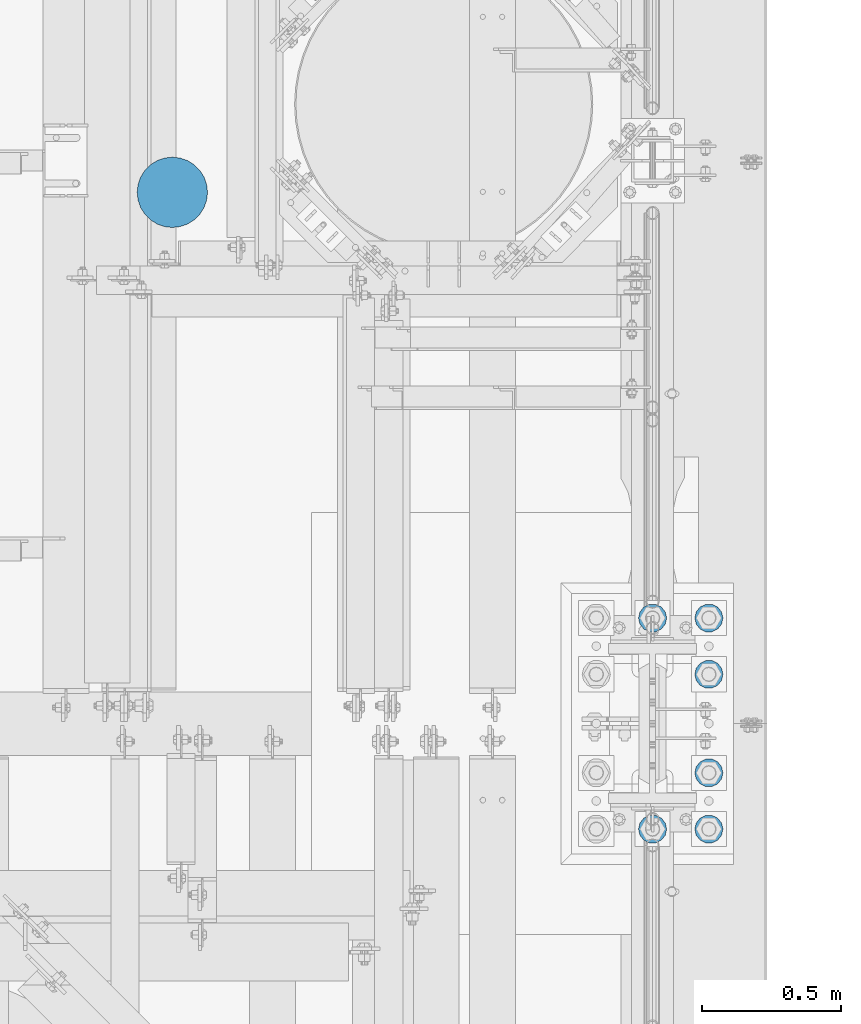
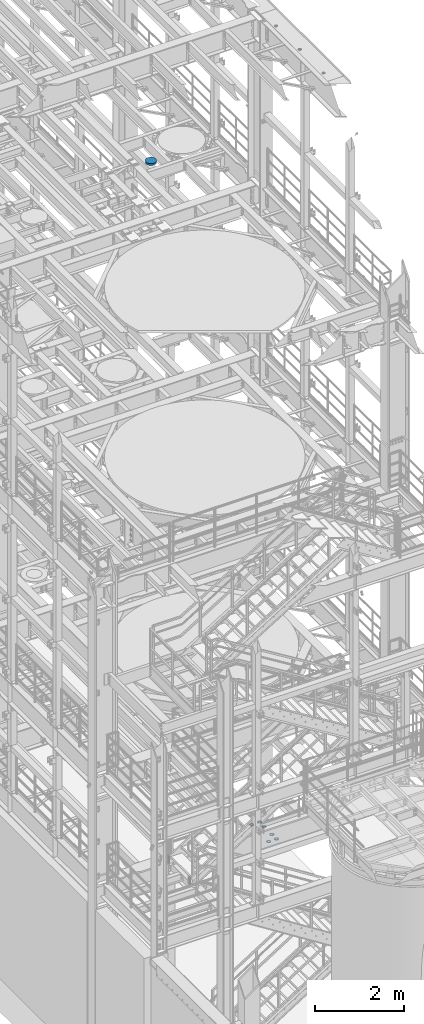
# One storey, part 841 of 1876: 7 columns, 2 elements without a shape of their own.
"""IFC2X3 building model written with IfcOpenShell, lengths in millimetres."""

from ifc_helpers import new_model, si_unit, frame, origin_with_axes, place, context, subcontext, project, spatial, faceted_brep, material, type_object, element, aggregate, save


model = new_model("IFC2X3")

# Units and contexts
model_context = context("Model", 3, precision=1e-05, world=origin_with_axes())
body_context = subcontext(model_context, "Body", "Model", "MODEL_VIEW")
ifc_project = project(units=[si_unit("LENGTHUNIT", "METRE", prefix="MILLI"), si_unit("AREAUNIT", "SQUARE_METRE"), si_unit("VOLUMEUNIT", "CUBIC_METRE"), si_unit("MASSUNIT", "GRAM", prefix="KILO"), si_unit("TIMEUNIT", "SECOND"), si_unit("PLANEANGLEUNIT", "RADIAN"), si_unit("SOLIDANGLEUNIT", "STERADIAN"), si_unit("THERMODYNAMICTEMPERATUREUNIT", "DEGREE_CELSIUS"), si_unit("LUMINOUSINTENSITYUNIT", "LUMEN")], contexts=[model_context])

# Site, building, storey
site_placement = place(None, origin_with_axes())
site = spatial("IfcSite", under=ifc_project, at=site_placement, CompositionType="ELEMENT")
building_placement = place(site_placement, origin_with_axes())
building = spatial("IfcBuilding", under=site, at=building_placement, Name="Undefined", CompositionType="ELEMENT")
storey_placement = place(building_placement, origin_with_axes())
storey = spatial("IfcBuildingStorey", under=building, at=storey_placement, Name="Undefined", CompositionType="ELEMENT", Elevation=0.0)

# Assembly, columns
assembly_1_placement = place(storey_placement, origin_with_axes())
assembly_1 = element("IfcElementAssembly", 1, at=assembly_1_placement, inside=storey, Name="TEMPLATE", AssemblyPlace="NOTDEFINED", PredefinedType="RIGID_FRAME")
ifc_material_1 = material(Name="STEEL/F436")
column_type_1 = type_object("IfcColumnType", Name="2_WASHER", PredefinedType="NOTDEFINED")
column_1_placement = place(assembly_1_placement, frame((7620.0, 1143.0, 38.1), z_axis=(0.0, -1.0, 0.0), x_axis=(0.0, 0.0, -1.0)))
column_1 = element("IfcColumn", 2, at=column_1_placement, type_object=column_type_1, material=ifc_material_1, Name="WASHER", ObjectType="2_WASHER", context=body_context, shape_type="Brep", body=[
    faceted_brep([(0.0, -50.7999992370605, 9.09494701772928e-13), (0.0, -45.7692178020588, -22.0412936161442), (4.7625, -45.7692178020588, -22.0412936161442), (4.7625, -50.7999992370605, 9.09494701772928e-13), (0.0, -31.6732814587394, -39.7170387128856), (4.7625, -31.6732814587394, -39.7170387128856), (0.0, -11.3040632752118, -49.5263371950259), (4.7625, -11.3040632752118, -49.5263371950259), (0.0, 11.30406327521, -49.5263371950264), (4.7625, 11.30406327521, -49.5263371950264), (0.0, 31.6732814587385, -39.7170387128867), (4.7625, 31.6732814587385, -39.7170387128867), (0.0, 45.7692178020579, -22.041293616146), (4.7625, 45.7692178020579, -22.041293616146), (0.0, 50.7999992370605, -9.09494701772928e-13), (4.7625, 50.7999992370605, -9.09494701772928e-13), (0.0, 45.7692178020588, 22.0412936161442), (4.7625, 45.7692178020588, 22.0412936161442), (0.0, 31.6732814587394, 39.7170387128856), (4.7625, 31.6732814587394, 39.7170387128856), (0.0, 11.3040632752118, 49.5263371950259), (4.7625, 11.3040632752118, 49.5263371950259), (0.0, -11.30406327521, 49.5263371950264), (4.7625, -11.30406327521, 49.5263371950264), (0.0, -31.6732814587385, 39.7170387128867), (4.7625, -31.6732814587385, 39.7170387128867), (0.0, -45.7692178020579, 22.041293616146), (4.7625, -45.7692178020579, 22.041293616146), (0.0, 0.0, 26.9869995117188), (0.0, 11.7093983825444, 24.3146012721213), (4.7625, 11.7093983825444, 24.3146012721213), (4.7625, 0.0, 26.9869995117188), (0.0, 21.0996520289491, 16.8262864224157), (4.7625, 21.0996520289491, 16.8262864224157), (0.0, 26.3108629296712, 6.00524193584533), (4.7625, 26.3108629296712, 6.00524193584533), (0.0, 26.3108629296712, -6.00524193584533), (4.7625, 26.3108629296712, -6.00524193584533), (0.0, 21.0996520289491, -16.8262864224157), (4.7625, 21.0996520289491, -16.8262864224157), (0.0, 11.7093983825444, -24.3146012721213), (4.7625, 11.7093983825444, -24.3146012721213), (0.0, 0.0, -26.9869995117188), (4.7625, 0.0, -26.9869995117188), (0.0, -11.7093983825444, -24.3146012721213), (4.7625, -11.7093983825444, -24.3146012721213), (0.0, -21.0996520289491, -16.8262864224157), (4.7625, -21.0996520289491, -16.8262864224157), (0.0, -26.3108629296712, -6.00524193584533), (4.7625, -26.3108629296712, -6.00524193584533), (0.0, -26.3108629296712, 6.00524193584533), (4.7625, -26.3108629296712, 6.00524193584533), (0.0, -21.0996520289491, 16.8262864224157), (4.7625, -21.0996520289491, 16.8262864224157), (0.0, -11.7093983825444, 24.3146012721213), (4.7625, -11.7093983825444, 24.3146012721213)], [[[0, 1, 2, 3]], [[1, 4, 5, 2]], [[4, 6, 7, 5]], [[6, 8, 9, 7]], [[8, 10, 11, 9]], [[10, 12, 13, 11]], [[12, 14, 15, 13]], [[14, 16, 17, 15]], [[16, 18, 19, 17]], [[18, 20, 21, 19]], [[20, 22, 23, 21]], [[22, 24, 25, 23]], [[24, 26, 27, 25]], [[26, 0, 3, 27]], [[28, 29, 30, 31]], [[29, 32, 33, 30]], [[32, 34, 35, 33]], [[34, 36, 37, 35]], [[36, 38, 39, 37]], [[38, 40, 41, 39]], [[40, 42, 43, 41]], [[42, 44, 45, 43]], [[44, 46, 47, 45]], [[46, 48, 49, 47]], [[48, 50, 51, 49]], [[50, 52, 53, 51]], [[52, 54, 55, 53]], [[54, 28, 31, 55]], [[5, 7, 9, 11, 13, 15, 17, 19, 21, 23, 25, 27, 3, 2], [33, 35, 37, 39, 41, 43, 45, 47, 49, 51, 53, 55, 31, 30]], [[26, 24, 22, 20, 18, 16, 14, 12, 10, 8, 6, 4, 1, 0], [54, 52, 50, 48, 46, 44, 42, 40, 38, 36, 34, 32, 29, 28]]]),
])
column_2_placement = place(assembly_1_placement, frame((7823.2, 1143.0, 38.1), z_axis=(0.0, 1.0, 0.0), x_axis=(0.0, 0.0, -1.0)))
column_2 = element("IfcColumn", 3, at=column_2_placement, type_object=column_type_1, material=ifc_material_1, Name="WASHER", ObjectType="2_WASHER", context=body_context, shape_type="Brep", body=[
    faceted_brep([(0.0, -50.7999992370605, 9.09494701772928e-13), (0.0, -45.7692178020588, -22.0412936161442), (4.7625, -45.7692178020588, -22.0412936161442), (4.7625, -50.7999992370605, 9.09494701772928e-13), (0.0, -31.6732814587394, -39.7170387128856), (4.7625, -31.6732814587394, -39.7170387128856), (0.0, -11.3040632752118, -49.5263371950259), (4.7625, -11.3040632752118, -49.5263371950259), (0.0, 11.30406327521, -49.5263371950264), (4.7625, 11.30406327521, -49.5263371950264), (0.0, 31.6732814587385, -39.7170387128867), (4.7625, 31.6732814587385, -39.7170387128867), (0.0, 45.7692178020579, -22.041293616146), (4.7625, 45.7692178020579, -22.041293616146), (0.0, 50.7999992370605, -9.09494701772928e-13), (4.7625, 50.7999992370605, -9.09494701772928e-13), (0.0, 45.7692178020588, 22.0412936161442), (4.7625, 45.7692178020588, 22.0412936161442), (0.0, 31.6732814587394, 39.7170387128856), (4.7625, 31.6732814587394, 39.7170387128856), (0.0, 11.3040632752118, 49.5263371950259), (4.7625, 11.3040632752118, 49.5263371950259), (0.0, -11.30406327521, 49.5263371950264), (4.7625, -11.30406327521, 49.5263371950264), (0.0, -31.6732814587385, 39.7170387128867), (4.7625, -31.6732814587385, 39.7170387128867), (0.0, -45.7692178020579, 22.041293616146), (4.7625, -45.7692178020579, 22.041293616146), (0.0, 0.0, 26.9869995117188), (0.0, 11.7093983825444, 24.3146012721213), (4.7625, 11.7093983825444, 24.3146012721213), (4.7625, 0.0, 26.9869995117188), (0.0, 21.0996520289491, 16.8262864224157), (4.7625, 21.0996520289491, 16.8262864224157), (0.0, 26.3108629296712, 6.00524193584533), (4.7625, 26.3108629296712, 6.00524193584533), (0.0, 26.3108629296712, -6.00524193584533), (4.7625, 26.3108629296712, -6.00524193584533), (0.0, 21.0996520289491, -16.8262864224157), (4.7625, 21.0996520289491, -16.8262864224157), (0.0, 11.7093983825444, -24.3146012721213), (4.7625, 11.7093983825444, -24.3146012721213), (0.0, 0.0, -26.9869995117188), (4.7625, 0.0, -26.9869995117188), (0.0, -11.7093983825444, -24.3146012721213), (4.7625, -11.7093983825444, -24.3146012721213), (0.0, -21.0996520289491, -16.8262864224157), (4.7625, -21.0996520289491, -16.8262864224157), (0.0, -26.3108629296712, -6.00524193584533), (4.7625, -26.3108629296712, -6.00524193584533), (0.0, -26.3108629296712, 6.00524193584533), (4.7625, -26.3108629296712, 6.00524193584533), (0.0, -21.0996520289491, 16.8262864224157), (4.7625, -21.0996520289491, 16.8262864224157), (0.0, -11.7093983825444, 24.3146012721213), (4.7625, -11.7093983825444, 24.3146012721213)], [[[0, 1, 2, 3]], [[1, 4, 5, 2]], [[4, 6, 7, 5]], [[6, 8, 9, 7]], [[8, 10, 11, 9]], [[10, 12, 13, 11]], [[12, 14, 15, 13]], [[14, 16, 17, 15]], [[16, 18, 19, 17]], [[18, 20, 21, 19]], [[20, 22, 23, 21]], [[22, 24, 25, 23]], [[24, 26, 27, 25]], [[26, 0, 3, 27]], [[28, 29, 30, 31]], [[29, 32, 33, 30]], [[32, 34, 35, 33]], [[34, 36, 37, 35]], [[36, 38, 39, 37]], [[38, 40, 41, 39]], [[40, 42, 43, 41]], [[42, 44, 45, 43]], [[44, 46, 47, 45]], [[46, 48, 49, 47]], [[48, 50, 51, 49]], [[50, 52, 53, 51]], [[52, 54, 55, 53]], [[54, 28, 31, 55]], [[5, 7, 9, 11, 13, 15, 17, 19, 21, 23, 25, 27, 3, 2], [33, 35, 37, 39, 41, 43, 45, 47, 49, 51, 53, 55, 31, 30]], [[26, 24, 22, 20, 18, 16, 14, 12, 10, 8, 6, 4, 1, 0], [54, 52, 50, 48, 46, 44, 42, 40, 38, 36, 34, 32, 29, 28]]]),
])
column_3_placement = place(assembly_1_placement, frame((7823.2, 1346.2, 38.1), z_axis=(0.0, 1.0, 0.0), x_axis=(0.0, 0.0, -1.0)))
column_3 = element("IfcColumn", 4, at=column_3_placement, type_object=column_type_1, material=ifc_material_1, Name="WASHER", ObjectType="2_WASHER", context=body_context, shape_type="Brep", body=[
    faceted_brep([(0.0, -50.7999992370605, 9.09494701772928e-13), (0.0, -45.7692178020588, -22.0412936161442), (4.7625, -45.7692178020588, -22.0412936161442), (4.7625, -50.7999992370605, 9.09494701772928e-13), (0.0, -31.6732814587394, -39.7170387128856), (4.7625, -31.6732814587394, -39.7170387128856), (0.0, -11.3040632752118, -49.5263371950259), (4.7625, -11.3040632752118, -49.5263371950259), (0.0, 11.30406327521, -49.5263371950264), (4.7625, 11.30406327521, -49.5263371950264), (0.0, 31.6732814587385, -39.7170387128867), (4.7625, 31.6732814587385, -39.7170387128867), (0.0, 45.7692178020579, -22.041293616146), (4.7625, 45.7692178020579, -22.041293616146), (0.0, 50.7999992370605, -9.09494701772928e-13), (4.7625, 50.7999992370605, -9.09494701772928e-13), (0.0, 45.7692178020588, 22.0412936161442), (4.7625, 45.7692178020588, 22.0412936161442), (0.0, 31.6732814587394, 39.7170387128856), (4.7625, 31.6732814587394, 39.7170387128856), (0.0, 11.3040632752118, 49.5263371950259), (4.7625, 11.3040632752118, 49.5263371950259), (0.0, -11.30406327521, 49.5263371950264), (4.7625, -11.30406327521, 49.5263371950264), (0.0, -31.6732814587385, 39.7170387128867), (4.7625, -31.6732814587385, 39.7170387128867), (0.0, -45.7692178020579, 22.041293616146), (4.7625, -45.7692178020579, 22.041293616146), (0.0, 0.0, 26.9869995117188), (0.0, 11.7093983825444, 24.3146012721213), (4.7625, 11.7093983825444, 24.3146012721213), (4.7625, 0.0, 26.9869995117188), (0.0, 21.0996520289491, 16.8262864224157), (4.7625, 21.0996520289491, 16.8262864224157), (0.0, 26.3108629296712, 6.00524193584533), (4.7625, 26.3108629296712, 6.00524193584533), (0.0, 26.3108629296712, -6.00524193584533), (4.7625, 26.3108629296712, -6.00524193584533), (0.0, 21.0996520289491, -16.8262864224157), (4.7625, 21.0996520289491, -16.8262864224157), (0.0, 11.7093983825444, -24.3146012721213), (4.7625, 11.7093983825444, -24.3146012721213), (0.0, 0.0, -26.9869995117188), (4.7625, 0.0, -26.9869995117188), (0.0, -11.7093983825444, -24.3146012721213), (4.7625, -11.7093983825444, -24.3146012721213), (0.0, -21.0996520289491, -16.8262864224157), (4.7625, -21.0996520289491, -16.8262864224157), (0.0, -26.3108629296712, -6.00524193584533), (4.7625, -26.3108629296712, -6.00524193584533), (0.0, -26.3108629296712, 6.00524193584533), (4.7625, -26.3108629296712, 6.00524193584533), (0.0, -21.0996520289491, 16.8262864224157), (4.7625, -21.0996520289491, 16.8262864224157), (0.0, -11.7093983825444, 24.3146012721213), (4.7625, -11.7093983825444, 24.3146012721213)], [[[0, 1, 2, 3]], [[1, 4, 5, 2]], [[4, 6, 7, 5]], [[6, 8, 9, 7]], [[8, 10, 11, 9]], [[10, 12, 13, 11]], [[12, 14, 15, 13]], [[14, 16, 17, 15]], [[16, 18, 19, 17]], [[18, 20, 21, 19]], [[20, 22, 23, 21]], [[22, 24, 25, 23]], [[24, 26, 27, 25]], [[26, 0, 3, 27]], [[28, 29, 30, 31]], [[29, 32, 33, 30]], [[32, 34, 35, 33]], [[34, 36, 37, 35]], [[36, 38, 39, 37]], [[38, 40, 41, 39]], [[40, 42, 43, 41]], [[42, 44, 45, 43]], [[44, 46, 47, 45]], [[46, 48, 49, 47]], [[48, 50, 51, 49]], [[50, 52, 53, 51]], [[52, 54, 55, 53]], [[54, 28, 31, 55]], [[5, 7, 9, 11, 13, 15, 17, 19, 21, 23, 25, 27, 3, 2], [33, 35, 37, 39, 41, 43, 45, 47, 49, 51, 53, 55, 31, 30]], [[26, 24, 22, 20, 18, 16, 14, 12, 10, 8, 6, 4, 1, 0], [54, 52, 50, 48, 46, 44, 42, 40, 38, 36, 34, 32, 29, 28]]]),
])
column_4_placement = place(assembly_1_placement, frame((7823.2, 1701.8, 38.1), z_axis=(0.0, 1.0, 0.0), x_axis=(0.0, 0.0, -1.0)))
column_4 = element("IfcColumn", 5, at=column_4_placement, type_object=column_type_1, material=ifc_material_1, Name="WASHER", ObjectType="2_WASHER", context=body_context, shape_type="Brep", body=[
    faceted_brep([(0.0, -50.7999992370605, 9.09494701772928e-13), (0.0, -45.7692178020588, -22.0412936161442), (4.7625, -45.7692178020588, -22.0412936161442), (4.7625, -50.7999992370605, 9.09494701772928e-13), (0.0, -31.6732814587394, -39.7170387128856), (4.7625, -31.6732814587394, -39.7170387128856), (0.0, -11.3040632752118, -49.5263371950259), (4.7625, -11.3040632752118, -49.5263371950259), (0.0, 11.30406327521, -49.5263371950264), (4.7625, 11.30406327521, -49.5263371950264), (0.0, 31.6732814587385, -39.7170387128867), (4.7625, 31.6732814587385, -39.7170387128867), (0.0, 45.7692178020579, -22.041293616146), (4.7625, 45.7692178020579, -22.041293616146), (0.0, 50.7999992370605, -9.09494701772928e-13), (4.7625, 50.7999992370605, -9.09494701772928e-13), (0.0, 45.7692178020588, 22.0412936161442), (4.7625, 45.7692178020588, 22.0412936161442), (0.0, 31.6732814587394, 39.7170387128856), (4.7625, 31.6732814587394, 39.7170387128856), (0.0, 11.3040632752118, 49.5263371950259), (4.7625, 11.3040632752118, 49.5263371950259), (0.0, -11.30406327521, 49.5263371950264), (4.7625, -11.30406327521, 49.5263371950264), (0.0, -31.6732814587385, 39.7170387128867), (4.7625, -31.6732814587385, 39.7170387128867), (0.0, -45.7692178020579, 22.041293616146), (4.7625, -45.7692178020579, 22.041293616146), (0.0, 0.0, 26.9869995117188), (0.0, 11.7093983825444, 24.3146012721213), (4.7625, 11.7093983825444, 24.3146012721213), (4.7625, 0.0, 26.9869995117188), (0.0, 21.0996520289491, 16.8262864224157), (4.7625, 21.0996520289491, 16.8262864224157), (0.0, 26.3108629296712, 6.00524193584533), (4.7625, 26.3108629296712, 6.00524193584533), (0.0, 26.3108629296712, -6.00524193584533), (4.7625, 26.3108629296712, -6.00524193584533), (0.0, 21.0996520289491, -16.8262864224157), (4.7625, 21.0996520289491, -16.8262864224157), (0.0, 11.7093983825444, -24.3146012721213), (4.7625, 11.7093983825444, -24.3146012721213), (0.0, 0.0, -26.9869995117188), (4.7625, 0.0, -26.9869995117188), (0.0, -11.7093983825444, -24.3146012721213), (4.7625, -11.7093983825444, -24.3146012721213), (0.0, -21.0996520289491, -16.8262864224157), (4.7625, -21.0996520289491, -16.8262864224157), (0.0, -26.3108629296712, -6.00524193584533), (4.7625, -26.3108629296712, -6.00524193584533), (0.0, -26.3108629296712, 6.00524193584533), (4.7625, -26.3108629296712, 6.00524193584533), (0.0, -21.0996520289491, 16.8262864224157), (4.7625, -21.0996520289491, 16.8262864224157), (0.0, -11.7093983825444, 24.3146012721213), (4.7625, -11.7093983825444, 24.3146012721213)], [[[0, 1, 2, 3]], [[1, 4, 5, 2]], [[4, 6, 7, 5]], [[6, 8, 9, 7]], [[8, 10, 11, 9]], [[10, 12, 13, 11]], [[12, 14, 15, 13]], [[14, 16, 17, 15]], [[16, 18, 19, 17]], [[18, 20, 21, 19]], [[20, 22, 23, 21]], [[22, 24, 25, 23]], [[24, 26, 27, 25]], [[26, 0, 3, 27]], [[28, 29, 30, 31]], [[29, 32, 33, 30]], [[32, 34, 35, 33]], [[34, 36, 37, 35]], [[36, 38, 39, 37]], [[38, 40, 41, 39]], [[40, 42, 43, 41]], [[42, 44, 45, 43]], [[44, 46, 47, 45]], [[46, 48, 49, 47]], [[48, 50, 51, 49]], [[50, 52, 53, 51]], [[52, 54, 55, 53]], [[54, 28, 31, 55]], [[5, 7, 9, 11, 13, 15, 17, 19, 21, 23, 25, 27, 3, 2], [33, 35, 37, 39, 41, 43, 45, 47, 49, 51, 53, 55, 31, 30]], [[26, 24, 22, 20, 18, 16, 14, 12, 10, 8, 6, 4, 1, 0], [54, 52, 50, 48, 46, 44, 42, 40, 38, 36, 34, 32, 29, 28]]]),
])
column_5_placement = place(assembly_1_placement, frame((7620.0, 1905.0, 38.1), z_axis=(0.0, -1.0, 0.0), x_axis=(0.0, 0.0, -1.0)))
column_5 = element("IfcColumn", 6, at=column_5_placement, type_object=column_type_1, material=ifc_material_1, Name="WASHER", ObjectType="2_WASHER", context=body_context, shape_type="Brep", body=[
    faceted_brep([(0.0, -50.7999992370605, 9.09494701772928e-13), (0.0, -45.7692178020588, -22.0412936161442), (4.7625, -45.7692178020588, -22.0412936161442), (4.7625, -50.7999992370605, 9.09494701772928e-13), (0.0, -31.6732814587394, -39.7170387128856), (4.7625, -31.6732814587394, -39.7170387128856), (0.0, -11.3040632752118, -49.5263371950259), (4.7625, -11.3040632752118, -49.5263371950259), (0.0, 11.30406327521, -49.5263371950264), (4.7625, 11.30406327521, -49.5263371950264), (0.0, 31.6732814587385, -39.7170387128867), (4.7625, 31.6732814587385, -39.7170387128867), (0.0, 45.7692178020579, -22.041293616146), (4.7625, 45.7692178020579, -22.041293616146), (0.0, 50.7999992370605, -9.09494701772928e-13), (4.7625, 50.7999992370605, -9.09494701772928e-13), (0.0, 45.7692178020588, 22.0412936161442), (4.7625, 45.7692178020588, 22.0412936161442), (0.0, 31.6732814587394, 39.7170387128856), (4.7625, 31.6732814587394, 39.7170387128856), (0.0, 11.3040632752118, 49.5263371950259), (4.7625, 11.3040632752118, 49.5263371950259), (0.0, -11.30406327521, 49.5263371950264), (4.7625, -11.30406327521, 49.5263371950264), (0.0, -31.6732814587385, 39.7170387128867), (4.7625, -31.6732814587385, 39.7170387128867), (0.0, -45.7692178020579, 22.041293616146), (4.7625, -45.7692178020579, 22.041293616146), (0.0, 0.0, 26.9869995117188), (0.0, 11.7093983825444, 24.3146012721213), (4.7625, 11.7093983825444, 24.3146012721213), (4.7625, 0.0, 26.9869995117188), (0.0, 21.0996520289491, 16.8262864224157), (4.7625, 21.0996520289491, 16.8262864224157), (0.0, 26.3108629296712, 6.00524193584533), (4.7625, 26.3108629296712, 6.00524193584533), (0.0, 26.3108629296712, -6.00524193584533), (4.7625, 26.3108629296712, -6.00524193584533), (0.0, 21.0996520289491, -16.8262864224157), (4.7625, 21.0996520289491, -16.8262864224157), (0.0, 11.7093983825444, -24.3146012721213), (4.7625, 11.7093983825444, -24.3146012721213), (0.0, 0.0, -26.9869995117188), (4.7625, 0.0, -26.9869995117188), (0.0, -11.7093983825444, -24.3146012721213), (4.7625, -11.7093983825444, -24.3146012721213), (0.0, -21.0996520289491, -16.8262864224157), (4.7625, -21.0996520289491, -16.8262864224157), (0.0, -26.3108629296712, -6.00524193584533), (4.7625, -26.3108629296712, -6.00524193584533), (0.0, -26.3108629296712, 6.00524193584533), (4.7625, -26.3108629296712, 6.00524193584533), (0.0, -21.0996520289491, 16.8262864224157), (4.7625, -21.0996520289491, 16.8262864224157), (0.0, -11.7093983825444, 24.3146012721213), (4.7625, -11.7093983825444, 24.3146012721213)], [[[0, 1, 2, 3]], [[1, 4, 5, 2]], [[4, 6, 7, 5]], [[6, 8, 9, 7]], [[8, 10, 11, 9]], [[10, 12, 13, 11]], [[12, 14, 15, 13]], [[14, 16, 17, 15]], [[16, 18, 19, 17]], [[18, 20, 21, 19]], [[20, 22, 23, 21]], [[22, 24, 25, 23]], [[24, 26, 27, 25]], [[26, 0, 3, 27]], [[28, 29, 30, 31]], [[29, 32, 33, 30]], [[32, 34, 35, 33]], [[34, 36, 37, 35]], [[36, 38, 39, 37]], [[38, 40, 41, 39]], [[40, 42, 43, 41]], [[42, 44, 45, 43]], [[44, 46, 47, 45]], [[46, 48, 49, 47]], [[48, 50, 51, 49]], [[50, 52, 53, 51]], [[52, 54, 55, 53]], [[54, 28, 31, 55]], [[5, 7, 9, 11, 13, 15, 17, 19, 21, 23, 25, 27, 3, 2], [33, 35, 37, 39, 41, 43, 45, 47, 49, 51, 53, 55, 31, 30]], [[26, 24, 22, 20, 18, 16, 14, 12, 10, 8, 6, 4, 1, 0], [54, 52, 50, 48, 46, 44, 42, 40, 38, 36, 34, 32, 29, 28]]]),
])
column_6_placement = place(assembly_1_placement, frame((7823.2, 1905.0, 38.1), z_axis=(0.0, 1.0, 0.0), x_axis=(0.0, 0.0, -1.0)))
column_6 = element("IfcColumn", 7, at=column_6_placement, type_object=column_type_1, material=ifc_material_1, Name="WASHER", ObjectType="2_WASHER", context=body_context, shape_type="Brep", body=[
    faceted_brep([(0.0, -50.7999992370605, 9.09494701772928e-13), (0.0, -45.7692178020588, -22.0412936161442), (4.7625, -45.7692178020588, -22.0412936161442), (4.7625, -50.7999992370605, 9.09494701772928e-13), (0.0, -31.6732814587394, -39.7170387128856), (4.7625, -31.6732814587394, -39.7170387128856), (0.0, -11.3040632752118, -49.5263371950259), (4.7625, -11.3040632752118, -49.5263371950259), (0.0, 11.30406327521, -49.5263371950264), (4.7625, 11.30406327521, -49.5263371950264), (0.0, 31.6732814587385, -39.7170387128867), (4.7625, 31.6732814587385, -39.7170387128867), (0.0, 45.7692178020579, -22.041293616146), (4.7625, 45.7692178020579, -22.041293616146), (0.0, 50.7999992370605, -9.09494701772928e-13), (4.7625, 50.7999992370605, -9.09494701772928e-13), (0.0, 45.7692178020588, 22.0412936161442), (4.7625, 45.7692178020588, 22.0412936161442), (0.0, 31.6732814587394, 39.7170387128856), (4.7625, 31.6732814587394, 39.7170387128856), (0.0, 11.3040632752118, 49.5263371950259), (4.7625, 11.3040632752118, 49.5263371950259), (0.0, -11.30406327521, 49.5263371950264), (4.7625, -11.30406327521, 49.5263371950264), (0.0, -31.6732814587385, 39.7170387128867), (4.7625, -31.6732814587385, 39.7170387128867), (0.0, -45.7692178020579, 22.041293616146), (4.7625, -45.7692178020579, 22.041293616146), (0.0, 0.0, 26.9869995117188), (0.0, 11.7093983825444, 24.3146012721213), (4.7625, 11.7093983825444, 24.3146012721213), (4.7625, 0.0, 26.9869995117188), (0.0, 21.0996520289491, 16.8262864224157), (4.7625, 21.0996520289491, 16.8262864224157), (0.0, 26.3108629296712, 6.00524193584533), (4.7625, 26.3108629296712, 6.00524193584533), (0.0, 26.3108629296712, -6.00524193584533), (4.7625, 26.3108629296712, -6.00524193584533), (0.0, 21.0996520289491, -16.8262864224157), (4.7625, 21.0996520289491, -16.8262864224157), (0.0, 11.7093983825444, -24.3146012721213), (4.7625, 11.7093983825444, -24.3146012721213), (0.0, 0.0, -26.9869995117188), (4.7625, 0.0, -26.9869995117188), (0.0, -11.7093983825444, -24.3146012721213), (4.7625, -11.7093983825444, -24.3146012721213), (0.0, -21.0996520289491, -16.8262864224157), (4.7625, -21.0996520289491, -16.8262864224157), (0.0, -26.3108629296712, -6.00524193584533), (4.7625, -26.3108629296712, -6.00524193584533), (0.0, -26.3108629296712, 6.00524193584533), (4.7625, -26.3108629296712, 6.00524193584533), (0.0, -21.0996520289491, 16.8262864224157), (4.7625, -21.0996520289491, 16.8262864224157), (0.0, -11.7093983825444, 24.3146012721213), (4.7625, -11.7093983825444, 24.3146012721213)], [[[0, 1, 2, 3]], [[1, 4, 5, 2]], [[4, 6, 7, 5]], [[6, 8, 9, 7]], [[8, 10, 11, 9]], [[10, 12, 13, 11]], [[12, 14, 15, 13]], [[14, 16, 17, 15]], [[16, 18, 19, 17]], [[18, 20, 21, 19]], [[20, 22, 23, 21]], [[22, 24, 25, 23]], [[24, 26, 27, 25]], [[26, 0, 3, 27]], [[28, 29, 30, 31]], [[29, 32, 33, 30]], [[32, 34, 35, 33]], [[34, 36, 37, 35]], [[36, 38, 39, 37]], [[38, 40, 41, 39]], [[40, 42, 43, 41]], [[42, 44, 45, 43]], [[44, 46, 47, 45]], [[46, 48, 49, 47]], [[48, 50, 51, 49]], [[50, 52, 53, 51]], [[52, 54, 55, 53]], [[54, 28, 31, 55]], [[5, 7, 9, 11, 13, 15, 17, 19, 21, 23, 25, 27, 3, 2], [33, 35, 37, 39, 41, 43, 45, 47, 49, 51, 53, 55, 31, 30]], [[26, 24, 22, 20, 18, 16, 14, 12, 10, 8, 6, 4, 1, 0], [54, 52, 50, 48, 46, 44, 42, 40, 38, 36, 34, 32, 29, 28]]]),
])
aggregate(assembly_1, [column_1, column_2, column_3, column_4, column_5, column_6])

# Assembly, column
assembly_2_placement = place(storey_placement, origin_with_axes())
assembly_2 = element("IfcElementAssembly", 8, at=assembly_2_placement, inside=storey, Name="COLUMN", AssemblyPlace="NOTDEFINED", PredefinedType="REINFORCEMENT_UNIT")
ifc_material_2 = material(Name="CONCRETE/3000")
column_type_2 = type_object("IfcColumnType", PredefinedType="NOTDEFINED")
column_7_placement = place(assembly_2_placement, frame((5886.45, 3441.7, 17932.4), z_axis=(-1.0, 0.0, 0.0), x_axis=(0.0, 0.0, 1.0)))
column_7 = element("IfcColumn", 9, at=column_7_placement, type_object=column_type_2, material=ifc_material_2, Name="COLUMN", context=body_context, shape_type="Brep", body=[
    faceted_brep([(0.0, -127.0, 0.0), (0.0, -123.815844847092, -28.260158612452), (50.7999999999993, -123.815844847092, -28.260158612452), (50.7999999999993, -127.0, 0.0), (0.0, -114.423046223607, -55.10323486793), (50.7999999999993, -114.423046223607, -55.10323486793), (0.0, -99.2925982734396, -79.1832048360593), (50.7999999999993, -99.2925982734396, -79.1832048360593), (0.0, -79.1832048360593, -99.2925982734396), (50.7999999999993, -79.1832048360593, -99.2925982734396), (0.0, -55.10323486793, -114.423046223607), (50.7999999999993, -55.10323486793, -114.423046223607), (0.0, -28.260158612452, -123.815844847091), (50.7999999999993, -28.260158612452, -123.815844847091), (0.0, 0.0, -127.0), (50.7999999999993, 0.0, -127.0), (0.0, 28.260158612452, -123.815844847091), (50.7999999999993, 28.260158612452, -123.815844847091), (0.0, 55.10323486793, -114.423046223607), (50.7999999999993, 55.10323486793, -114.423046223607), (0.0, 79.1832048360593, -99.2925982734396), (50.7999999999993, 79.1832048360593, -99.2925982734396), (0.0, 99.2925982734396, -79.1832048360593), (50.7999999999993, 99.2925982734396, -79.1832048360593), (0.0, 114.423046223607, -55.10323486793), (50.7999999999993, 114.423046223607, -55.10323486793), (0.0, 123.815844847092, -28.260158612452), (50.7999999999993, 123.815844847092, -28.260158612452), (0.0, 127.0, 0.0), (50.7999999999993, 127.0, 0.0), (0.0, 123.815844847092, 28.260158612452), (50.7999999999993, 123.815844847092, 28.260158612452), (0.0, 114.423046223607, 55.10323486793), (50.7999999999993, 114.423046223607, 55.10323486793), (0.0, 99.2925982734396, 79.1832048360593), (50.7999999999993, 99.2925982734396, 79.1832048360593), (0.0, 79.1832048360593, 99.2925982734396), (50.7999999999993, 79.1832048360593, 99.2925982734396), (0.0, 55.10323486793, 114.423046223607), (50.7999999999993, 55.10323486793, 114.423046223607), (0.0, 28.260158612452, 123.815844847091), (50.7999999999993, 28.260158612452, 123.815844847091), (0.0, 0.0, 127.0), (50.7999999999993, 0.0, 127.0), (0.0, -28.260158612452, 123.815844847091), (50.7999999999993, -28.260158612452, 123.815844847091), (0.0, -55.10323486793, 114.423046223607), (50.7999999999993, -55.10323486793, 114.423046223607), (0.0, -79.1832048360593, 99.2925982734396), (50.7999999999993, -79.1832048360593, 99.2925982734396), (0.0, -99.2925982734396, 79.1832048360593), (50.7999999999993, -99.2925982734396, 79.1832048360593), (0.0, -114.423046223607, 55.10323486793), (50.7999999999993, -114.423046223607, 55.10323486793), (0.0, -123.815844847092, 28.260158612452), (50.7999999999993, -123.815844847092, 28.260158612452)], [[[0, 1, 2, 3]], [[1, 4, 5, 2]], [[4, 6, 7, 5]], [[6, 8, 9, 7]], [[8, 10, 11, 9]], [[10, 12, 13, 11]], [[12, 14, 15, 13]], [[14, 16, 17, 15]], [[16, 18, 19, 17]], [[18, 20, 21, 19]], [[20, 22, 23, 21]], [[22, 24, 25, 23]], [[24, 26, 27, 25]], [[26, 28, 29, 27]], [[28, 30, 31, 29]], [[30, 32, 33, 31]], [[32, 34, 35, 33]], [[34, 36, 37, 35]], [[36, 38, 39, 37]], [[38, 40, 41, 39]], [[40, 42, 43, 41]], [[42, 44, 45, 43]], [[44, 46, 47, 45]], [[46, 48, 49, 47]], [[48, 50, 51, 49]], [[50, 52, 53, 51]], [[52, 54, 55, 53]], [[54, 0, 3, 55]], [[5, 7, 9, 11, 13, 15, 17, 19, 21, 23, 25, 27, 29, 31, 33, 35, 37, 39, 41, 43, 45, 47, 49, 51, 53, 55, 3, 2]], [[54, 52, 50, 48, 46, 44, 42, 40, 38, 36, 34, 32, 30, 28, 26, 24, 22, 20, 18, 16, 14, 12, 10, 8, 6, 4, 1, 0]]]),
])
aggregate(assembly_2, [column_7])

save(model, "model.ifc")
